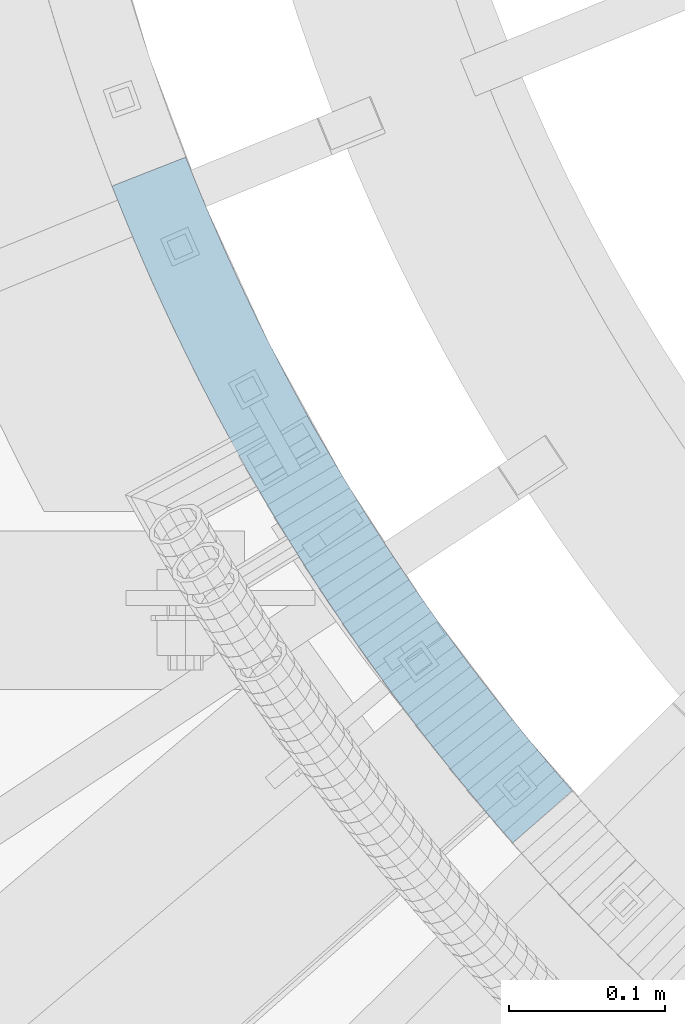
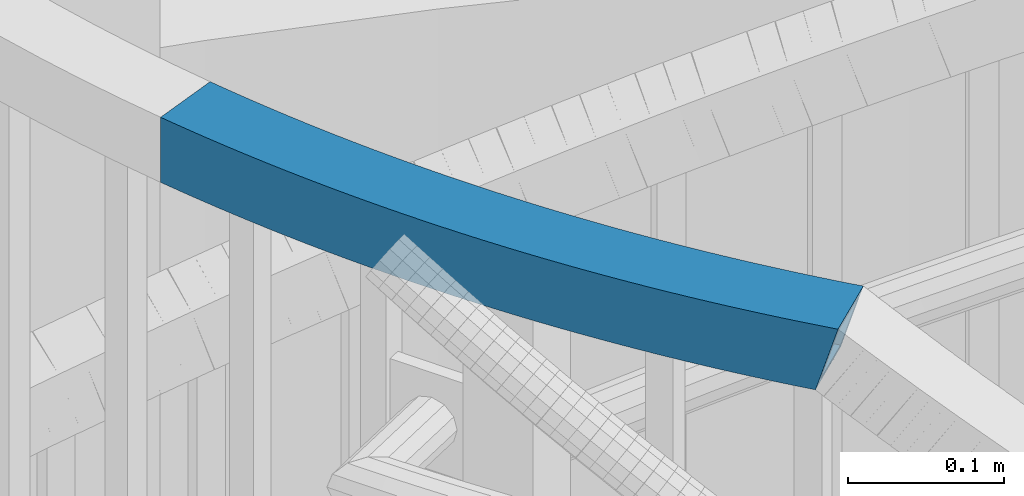
# One storey, part 475 of 975: 1 beam.
"""IFC2X3 building model written with IfcOpenShell, lengths in millimetres."""

from ifc_helpers import new_model, si_unit, frame, origin_with_axes, place, context, subcontext, project, spatial, faceted_brep, material, type_object, element, save


model = new_model("IFC2X3")

# Units and contexts
model_context = context("Model", 3, precision=1e-05, world=origin_with_axes())
body_context = subcontext(model_context, "Body", "Model", "MODEL_VIEW")
ifc_project = project(units=[si_unit("LENGTHUNIT", "METRE", prefix="MILLI"), si_unit("AREAUNIT", "SQUARE_METRE"), si_unit("VOLUMEUNIT", "CUBIC_METRE"), si_unit("MASSUNIT", "GRAM", prefix="KILO"), si_unit("TIMEUNIT", "SECOND"), si_unit("PLANEANGLEUNIT", "RADIAN"), si_unit("SOLIDANGLEUNIT", "STERADIAN"), si_unit("THERMODYNAMICTEMPERATUREUNIT", "DEGREE_CELSIUS"), si_unit("LUMINOUSINTENSITYUNIT", "LUMEN")], contexts=[model_context])

# Site, building, storey
site_placement = place(None, origin_with_axes())
site = spatial("IfcSite", under=ifc_project, at=site_placement, CompositionType="ELEMENT")
building_placement = place(site_placement, origin_with_axes())
building = spatial("IfcBuilding", under=site, at=building_placement, Name="Undefined", CompositionType="ELEMENT")
storey_placement = place(building_placement, origin_with_axes())
storey = spatial("IfcBuildingStorey", under=building, at=storey_placement, Name="Undefined", CompositionType="ELEMENT", Elevation=0.0)

# Beam
ifc_material = material()
beam_type = type_object("IfcBeamType", Name="HSS2X2X.188_TUBES", PredefinedType="NOTDEFINED")
beam_placement = place(storey_placement, frame((33730.3437735476, 2432.37434502385, 5130.8), z_axis=(0.0, 0.0, 1.0), x_axis=(-0.540589270770484, 0.841286657642825, 0.0)))
element("IfcBeam", 1, at=beam_placement, inside=storey, type_object=beam_type, material=ifc_material, Name="HANDRAIL", ObjectType="HSS2X2X.188_TUBES", context=body_context, shape_type="Brep", body=[
    faceted_brep([(79.5471046465154, 39.1947421820078, -25.3999999999996), (79.5471046465154, 39.1947421820078, 25.3999999999996), (88.9890045391239, 40.4672051726338, 25.3999999999996), (88.9890045391239, 40.4672051726338, -25.3999999999996), (98.4392155630703, 41.6763979808347, 25.3999999999996), (98.4392155630703, 41.6763979808347, -25.3999999999996), (107.897313749627, 42.8222663580855, 25.3999999999996), (107.897313749627, 42.8222663580855, -25.3999999999996), (117.362874776216, 43.9047588968242, 25.3999999999996), (117.362874776216, 43.9047588968242, -25.3999999999996), (126.835473985457, 44.9238270327405, 25.3999999999996), (126.835473985457, 44.9238270327405, -25.3999999999996), (136.314686404205, 45.8794250469546, 25.3999999999996), (136.314686404205, 45.8794250469546, -25.3999999999996), (145.800086762627, 46.7715100680834, 25.3999999999996), (145.800086762627, 46.7715100680834, -25.3999999999996), (155.291249513284, 47.6000420741329, 25.3999999999996), (155.291249513284, 47.6000420741329, -25.3999999999996), (164.787748850207, 48.3649838943456, 25.3999999999996), (164.787748850207, 48.3649838943456, -25.3999999999996), (174.289158728016, 49.0663012108089, 25.3999999999996), (174.289158728016, 49.0663012108089, -25.3999999999996), (183.795052881027, 49.7039625600446, 25.3999999999996), (183.795052881027, 49.7039625600446, -25.3999999999996), (193.30500484237, 50.2779393343772, 25.3999999999996), (193.30500484237, 50.2779393343772, -25.3999999999996), (202.818587963133, 50.7882057832503, 25.3999999999996), (202.818587963133, 50.7882057832503, -25.3999999999996), (212.335375431498, 51.2347390143768, 25.3999999999996), (212.335375431498, 51.2347390143768, -25.3999999999996), (221.854940291885, 51.6175189947426, 25.3999999999996), (221.854940291885, 51.6175189947426, -25.3999999999996), (231.376855464123, 51.9365285515378, 25.3999999999996), (231.376855464123, 51.9365285515378, -25.3999999999996), (240.900693762576, 52.191753372892, 25.3999999999996), (240.900693762576, 52.191753372892, -25.3999999999996), (250.426027915348, 52.3831820085652, 25.3999999999996), (250.426027915348, 52.3831820085652, -25.3999999999996), (259.952430583429, 52.5108058704027, 25.3999999999996), (259.952430583429, 52.5108058704027, -25.3999999999996), (269.479474379868, 52.5746192327679, 25.3999999999996), (269.479474379868, 52.5746192327679, -25.3999999999996), (279.00673188896, 52.5746192327751, 25.3999999999996), (279.00673188896, 52.5746192327751, -25.3999999999996), (288.533775685404, 52.5108058704245, 25.3999999999996), (288.533775685404, 52.5108058704245, -25.3999999999996), (298.060178353486, 52.3831820086016, 25.3999999999996), (298.060178353486, 52.3831820086016, -25.3999999999996), (307.585512506257, 52.1917533729429, 25.3999999999996), (307.585512506257, 52.1917533729429, -25.3999999999996), (317.109350804712, 51.9365285515996, 25.3999999999996), (317.109350804712, 51.9365285515996, -25.3999999999996), (326.631265976945, 51.6175189948226, 25.3999999999996), (326.631265976945, 51.6175189948226, -25.3999999999996), (336.150830837334, 51.2347390144678, 25.3999999999996), (336.150830837334, 51.2347390144678, -25.3999999999996), (345.667618305704, 50.7882057833631, 25.3999999999996), (345.667618305704, 50.7882057833631, -25.3999999999996), (355.181201426469, 50.2779393344972, 25.3999999999996), (355.181201426469, 50.2779393344972, -25.3999999999996), (364.69115338781, 49.7039625601756, 25.3999999999996), (364.69115338781, 49.7039625601756, -25.3999999999996), (374.197047540827, 49.0663012109617, 25.3999999999996), (374.197047540827, 49.0663012109617, -25.3999999999996), (383.698457418637, 48.3649838945094, 25.3999999999996), (383.698457418637, 48.3649838945094, -25.3999999999996), (393.19495675556, 47.6000420743076, 25.3999999999996), (393.19495675556, 47.6000420743076, -25.3999999999996), (402.686119506223, 46.771510068269, 25.3999999999996), (402.686119506223, 46.771510068269, -25.3999999999996), (412.171519864649, 45.8794250471583, 25.3999999999996), (412.171519864649, 45.8794250471583, -25.3999999999996), (421.650732283399, 44.9238270329552, 25.3999999999996), (421.650732283399, 44.9238270329552, -25.3999999999996), (431.123331492641, 43.9047588970534, 25.3999999999996), (431.123331492641, 43.9047588970534, -25.3999999999996), (440.588892519234, 42.8222663583329, 25.3999999999996), (440.588892519234, 42.8222663583329, -25.3999999999996), (450.046990705794, 41.676397981093, 25.3999999999996), (450.046990705794, 41.676397981093, -25.3999999999996), (459.497201729744, 40.4672051729103, 25.3999999999996), (459.497201729744, 40.4672051729103, -25.3999999999996), (468.939101622354, 39.1947421822952, 25.3999999999996), (468.939101622354, 39.1947421822952, -25.3999999999996), (478.372266787757, 37.8590660962946, 25.3999999999996), (478.372266787757, 37.8590660962946, -25.3999999999996), (487.796274021963, 36.4602368378837, 25.3999999999996), (487.796274021963, 36.4602368378837, -25.3999999999996), (497.210700531834, 34.9983171633285, 25.3999999999996), (497.210700531834, 34.9983171633285, -25.3999999999996), (506.615123954047, 33.4733726593295, 25.3999999999996), (506.615123954047, 33.4733726593295, -25.3999999999996), (516.00912237406, 31.8854717401045, 25.3999999999996), (516.00912237406, 31.8854717401045, -25.3999999999996), (525.39227434504, 30.2346856443182, 25.3999999999996), (525.39227434504, 30.2346856443182, -25.3999999999996), (534.764158906748, 28.5210884318549, 25.3999999999996), (534.764158906748, 28.5210884318549, -25.3999999999996), (544.124355604452, 26.744756980559, 25.3999999999996), (544.124355604452, 26.744756980559, -25.3999999999996), (534.485739444877, -23.1324630554082, 25.3999999999996), (534.485739444877, -23.1324630554082, -25.3999999999996), (543.499968030215, -24.9057709819099, -25.3999999999996), (543.499968030215, -24.9057709819099, 25.3999999999996), (525.459835486381, -21.4195720130774, 25.3999999999996), (525.459835486381, -21.4195720130774, -25.3999999999996), (516.422661087592, -19.7671747010645, 25.3999999999996), (516.422661087592, -19.7671747010645, -25.3999999999996), (507.374621687002, -18.175345251555, 25.3999999999996), (507.374621687002, -18.175345251555, -25.3999999999996), (498.316123210558, -16.644155079448, 25.3999999999996), (498.316123210558, -16.644155079448, -25.3999999999996), (489.247572053426, -15.1736728791657, 25.3999999999996), (489.247572053426, -15.1736728791657, -25.3999999999996), (480.169375061769, -13.7639646215539, 25.3999999999996), (480.169375061769, -13.7639646215539, -25.3999999999996), (471.081939514499, -12.4150935509497, 25.3999999999996), (471.081939514499, -12.4150935509497, -25.3999999999996), (461.985673105, -11.1271201823001, 25.3999999999996), (461.985673105, -11.1271201823001, -25.3999999999996), (452.880983922843, -9.90010229849213, 25.3999999999996), (452.880983922843, -9.90010229849213, -25.3999999999996), (443.768280435463, -8.73409494774387, 25.3999999999996), (443.768280435463, -8.73409494774387, -25.3999999999996), (434.647971469851, -7.62915044112378, 25.3999999999996), (434.647971469851, -7.62915044112378, -25.3999999999996), (425.520466194208, -6.58531835020767, 25.3999999999996), (425.520466194208, -6.58531835020767, -25.3999999999996), (416.386174099582, -5.60264550488137, 25.3999999999996), (416.386174099582, -5.60264550488137, -25.3999999999996), (407.245504981502, -4.68117599118341, 25.3999999999996), (407.245504981502, -4.68117599118341, -25.3999999999996), (398.09886892159, -3.82095114939875, 25.3999999999996), (398.09886892159, -3.82095114939875, -25.3999999999996), (388.946676269168, -3.02200957214518, 25.3999999999996), (388.946676269168, -3.02200957214518, -25.3999999999996), (379.789337622846, -2.2843871026671, 25.3999999999996), (379.789337622846, -2.2843871026671, -25.3999999999996), (370.627263812099, -1.60811683322754, 25.3999999999996), (370.627263812099, -1.60811683322754, -25.3999999999996), (361.460865878833, -0.993229103627527, 25.3999999999996), (361.460865878833, -0.993229103627527, -25.3999999999996), (352.290555058969, -0.439751499816339, 25.3999999999996), (352.290555058969, -0.439751499816339, -25.3999999999996), (343.116742763947, 0.0522911472980923, 25.3999999999996), (343.116742763947, 0.0522911472980923, -25.3999999999996), (333.939840562307, 0.482876763009699, 25.3999999999996), (333.939840562307, 0.482876763009699, -25.3999999999996), (324.760260161214, 0.851986029774707, 25.3999999999996), (324.760260161214, 0.851986029774707, -25.3999999999996), (315.578413387988, 1.1596023880993, 25.3999999999996), (315.578413387988, 1.1596023880993, -25.3999999999996), (306.394712171623, 1.40571203724903, 25.3999999999996), (306.394712171623, 1.40571203724903, -25.3999999999996), (297.209568524308, 1.59030393592184, 25.3999999999996), (297.209568524308, 1.59030393592184, -25.3999999999996), (288.023394522939, 1.71336980267733, 25.3999999999996), (288.023394522939, 1.71336980267733, -25.3999999999996), (278.836602290661, 1.77490411638064, 25.3999999999996), (278.836602290661, 1.77490411638064, -25.3999999999996), (269.649603978318, 1.77490411636609, 25.3999999999996), (269.649603978318, 1.77490411636609, -25.3999999999996), (260.462811746042, 1.71336980266278, 25.3999999999996), (260.462811746042, 1.71336980266278, -25.3999999999996), (251.276637744675, 1.59030393588546, 25.3999999999996), (251.276637744675, 1.59030393588546, -25.3999999999996), (242.091494097356, 1.40571203720174, 25.3999999999996), (242.091494097356, 1.40571203720174, -25.3999999999996), (232.907792880991, 1.15960238803382, 25.3999999999996), (232.907792880991, 1.15960238803382, -25.3999999999996), (223.725946107768, 0.851986029705586, 25.3999999999996), (223.725946107768, 0.851986029705586, -25.3999999999996), (214.546365706678, 0.482876762926026, 25.3999999999996), (214.546365706678, 0.482876762926026, -25.3999999999996), (205.36946350504, 0.0522911471962288, 25.3999999999996), (205.36946350504, 0.0522911471962288, -25.3999999999996), (196.195651210017, -0.439751499936392, 25.3999999999996), (196.195651210017, -0.439751499936392, -25.3999999999996), (187.02534039015, -0.993229103754857, 25.3999999999996), (187.02534039015, -0.993229103754857, -25.3999999999996), (177.858942456893, -1.60811683337306, 25.3999999999996), (177.858942456893, -1.60811683337306, -25.3999999999996), (168.696868646148, -2.28438710281989, 25.3999999999996), (168.696868646148, -2.28438710281989, -25.3999999999996), (159.539529999825, -3.02200957231253, 25.3999999999996), (159.539529999825, -3.02200957231253, -25.3999999999996), (150.387337347409, -3.82095114958065, 25.3999999999996), (150.387337347409, -3.82095114958065, -25.3999999999996), (141.240701287499, -4.68117599137986, 25.3999999999996), (141.240701287499, -4.68117599137986, -25.3999999999996), (132.100032169421, -5.60264550508509, 25.3999999999996), (132.100032169421, -5.60264550508509, -25.3999999999996), (122.965740074795, -6.58531835043686, 25.3999999999996), (122.965740074795, -6.58531835043686, -25.3999999999996), (113.838234799156, -7.62915044136025, 25.3999999999996), (113.838234799156, -7.62915044136025, -25.3999999999996), (104.717925833545, -8.73409494799853, 25.3999999999996), (104.717925833545, -8.73409494799853, -25.3999999999996), (95.6052223461702, -9.90010229876134, 25.3999999999996), (95.6052223461702, -9.90010229876134, -25.3999999999996), (86.500533164015, -11.127120182573, 25.3999999999996), (86.500533164015, -11.127120182573, -25.3999999999996), (68.3168312072576, -13.7639646218558, 25.3999999999996), (67.9397252692688, -13.8225235356222, 25.3999999999996), (68.3168312072576, -13.7639646218558, 24.1318825961562), (77.4042667545236, -12.4150935512334, 25.3999999999996), (77.4042667545236, -12.4150935512334, -6.39587451277657), (83.0671348327323, -11.6132675111185, -25.3999999999996), (553.472444507761, 24.905770982703, -25.3999999999996), (75.4261148838796, 38.6112362876302, -25.3999999999996), (70.1139394811162, 37.859066095989, 25.3999999999996), (70.1139394811162, 37.859066095989, -7.57277065792005), (60.6899322469162, 36.4602368375672, 25.3999999999996), (60.6899322469162, 36.4602368375672, 24.0856441217129), (60.2990761599049, 36.3995427312439, 25.3999999999996), (553.472444507761, 24.905770982703, 25.3999999999996), (80.1989885700332, 34.4770675853324, 20.6374999999998), (80.1989885700332, 34.4770675853324, -20.6374999999998), (89.6092749585368, 35.7452700971953, -20.6374999999998), (89.6092749585368, 35.7452700971953, 20.6374999999998), (99.0278446509274, 36.9504142687547, -20.6374999999998), (99.0278446509274, 36.9504142687547, 20.6374999999998), (108.45427509802, 38.0924460331371, -20.6374999999998), (108.45427509802, 38.0924460331371, 20.6374999999998), (117.888143397957, 39.1713141548935, -20.6374999999998), (117.888143397957, 39.1713141548935, 20.6374999999998), (127.329026315203, 40.1869702323165, -20.6374999999998), (127.329026315203, 40.1869702323165, 20.6374999999998), (136.776500299513, 41.1393686996053, -20.6374999999998), (136.776500299513, 41.1393686996053, 20.6374999999998), (146.230141504948, 42.0284668289205, -20.6374999999998), (146.230141504948, 42.0284668289205, 20.6374999999998), (155.689525808897, 42.8542247322803, -20.6374999999998), (155.689525808897, 42.8542247322803, 20.6374999999998), (165.154228831076, 43.6166053633569, -20.6374999999998), (165.154228831076, 43.6166053633569, 20.6374999999998), (174.6238259526, 44.3155745191725, -20.6374999999998), (174.6238259526, 44.3155745191725, 20.6374999999998), (184.09789233501, 44.9511008415648, -20.6374999999998), (184.09789233501, 44.9511008415648, 20.6374999999998), (193.576002939335, 45.5231558186606, -20.6374999999998), (193.576002939335, 45.5231558186606, 20.6374999999998), (203.057732545187, 46.0317137861239, -20.6374999999998), (203.057732545187, 46.0317137861239, 20.6374999999998), (212.542655769796, 46.4767519283014, -20.6374999999998), (212.542655769796, 46.4767519283014, 20.6374999999998), (222.030347087128, 46.8582502792706, -20.6374999999998), (222.030347087128, 46.8582502792706, 20.6374999999998), (231.520380846954, 47.1761917237091, -20.6374999999998), (231.520380846954, 47.1761917237091, 20.6374999999998), (241.012331293961, 47.4305619976731, -20.6374999999998), (241.012331293961, 47.4305619976731, 20.6374999999998), (250.505772586846, 47.6213496892524, -20.6374999999998), (250.505772586846, 47.6213496892524, 20.6374999999998), (260.000278817424, 47.7485462390505, -20.6374999999998), (260.000278817424, 47.7485462390505, 20.6374999999998), (269.495424029723, 47.8121459406029, -20.6374999999998), (269.495424029723, 47.8121459406029, 20.6374999999998), (278.99078223912, 47.8121459406175, -20.6374999999998), (278.99078223912, 47.8121459406175, 20.6374999999998), (288.485927451422, 47.7485462390759, -20.6374999999998), (288.485927451422, 47.7485462390759, 20.6374999999998), (297.980433682, 47.6213496892888, -20.6374999999998), (297.980433682, 47.6213496892888, 20.6374999999998), (307.473874974887, 47.4305619977204, -20.6374999999998), (307.473874974887, 47.4305619977204, 20.6374999999998), (316.965825421896, 47.1761917237709, -20.6374999999998), (316.965825421896, 47.1761917237709, 20.6374999999998), (326.455859181722, 46.8582502793433, -20.6374999999998), (326.455859181722, 46.8582502793433, 20.6374999999998), (335.943550499052, 46.476751928396, -20.6374999999998), (335.943550499052, 46.476751928396, 20.6374999999998), (345.428473723661, 46.0317137862257, -20.6374999999998), (345.428473723661, 46.0317137862257, 20.6374999999998), (354.910203329518, 45.5231558187807, -20.6374999999998), (354.910203329518, 45.5231558187807, 20.6374999999998), (364.388313933849, 44.9511008416994, -20.6374999999998), (364.388313933849, 44.9511008416994, 20.6374999999998), (373.862380316254, 44.3155745193144, -20.6374999999998), (373.862380316254, 44.3155745193144, 20.6374999999998), (383.331977437781, 43.6166053635243, -20.6374999999998), (383.331977437781, 43.6166053635243, 20.6374999999998), (392.796680459966, 42.8542247324549, -20.6374999999998), (392.796680459966, 42.8542247324549, 20.6374999999998), (402.256064763913, 42.0284668291097, -20.6374999999998), (402.256064763913, 42.0284668291097, 20.6374999999998), (411.709705969353, 41.139368699809, -20.6374999999998), (411.709705969353, 41.139368699809, 20.6374999999998), (421.157179953665, 40.1869702325312, -20.6374999999998), (421.157179953665, 40.1869702325312, 20.6374999999998), (430.598062870915, 39.1713141551227, -20.6374999999998), (430.598062870915, 39.1713141551227, 20.6374999999998), (440.031931170854, 38.0924460333845, -20.6374999999998), (440.031931170854, 38.0924460333845, 20.6374999999998), (449.458361617952, 36.9504142690203, -20.6374999999998), (449.458361617952, 36.9504142690203, 20.6374999999998), (458.876931310348, 35.7452700974682, -20.6374999999998), (458.876931310348, 35.7452700974682, 20.6374999999998), (468.287217698851, 34.4770675856162, -20.6374999999998), (468.287217698851, 34.4770675856162, 20.6374999999998), (477.688798605892, 33.1458636293646, -20.6374999999998), (477.688798605892, 33.1458636293646, 20.6374999999998), (487.081252244445, 31.7517179510614, -20.6374999999998), (487.081252244445, 31.7517179510614, 20.6374999999998), (496.464157236978, 30.2946930968428, -20.6374999999998), (496.464157236978, 30.2946930968428, 20.6374999999998), (505.837092634341, 28.7748544338137, -20.6374999999998), (505.837092634341, 28.7748544338137, 20.6374999999998), (515.199637934647, 27.1922701471376, -20.6374999999998), (515.199637934647, 27.1922701471376, 20.6374999999998), (524.551373102157, 25.5470112369403, -20.6374999999998), (524.551373102157, 25.5470112369403, 20.6374999999998), (533.891878586088, 23.8391515151488, -20.6374999999998), (533.891878586088, 23.8391515151488, 20.6374999999998), (543.22073533949, 22.0687676021844, -20.6374999999998), (543.22073533949, 22.0687676021844, 20.6374999999998), (552.537524837991, 20.2359389235207, -20.6374999999998), (552.537524837991, 20.2359389235207, 20.6374999999998), (544.434887699987, -20.2359389227277, 20.6374999999998), (544.434887699987, -20.2359389227277, -20.6374999999998), (535.389359709841, -18.4564736770335, -20.6374999999998), (535.389359709841, -18.4564736770335, 20.6374999999998), (526.332115807041, -16.7376350963677, -20.6374999999998), (526.332115807041, -16.7376350963677, 20.6374999999998), (517.263562330476, -15.0795002936866, -20.6374999999998), (517.263562330476, -15.0795002936866, 20.6374999999998), (508.184106126417, -13.482143658588, -20.6374999999998), (508.184106126417, -13.482143658588, 20.6374999999998), (499.094154530259, -11.9456368539431, -20.6374999999998), (499.094154530259, -11.9456368539431, 20.6374999999998), (489.994115348274, -10.4700488126837, -20.6374999999998), (489.994115348274, -10.4700488126837, 20.6374999999998), (480.884396839287, -9.05544573472798, -20.6374999999998), (480.884396839287, -9.05544573472798, 20.6374999999998), (471.765407696368, -7.7018910840161, -20.6374999999998), (471.765407696368, -7.7018910840161, 20.6374999999998), (462.6375570285, -6.40944558562114, -20.6374999999998), (462.6375570285, -6.40944558562114, 20.6374999999998), (453.50125434224, -5.17816722304997, -20.6374999999998), (453.50125434224, -5.17816722304997, 20.6374999999998), (444.356909523305, -4.00811123567109, -20.6374999999998), (444.356909523305, -4.00811123567109, 20.6374999999998), (435.204932818227, -2.89933011617904, -20.6374999999998), (435.204932818227, -2.89933011617904, 20.6374999999998), (426.045734815938, -1.85187360827695, -20.6374999999998), (426.045734815938, -1.85187360827695, 20.6374999999998), (416.879726429315, -0.865788704457373, -20.6374999999998), (416.879726429315, -0.865788704457373, 20.6374999999998), (407.707318876795, 0.0588803561549867, -20.6374999999998), (407.707318876795, 0.0588803561549867, 20.6374999999998), (398.528923663896, 0.922092089753278, -20.6374999999998), (398.528923663896, 0.922092089753278, 20.6374999999998), (389.344952564767, 1.72380776971113, -20.6374999999998), (389.344952564767, 1.72380776971113, 20.6374999999998), (380.155817603702, 2.46399142831797, -20.6374999999998), (380.155817603702, 2.46399142831797, 20.6374999999998), (370.961931036665, 3.14260985841247, -20.6374999999998), (370.961931036665, 3.14260985841247, 20.6374999999998), (361.763705332804, 3.75963261485958, -20.6374999999998), (361.763705332804, 3.75963261485958, 20.6374999999998), (352.561553155925, 4.31503201590021, -20.6374999999998), (352.561553155925, 4.31503201590021, 20.6374999999998), (343.355887345982, 4.80878314442452, -20.6374999999998), (343.355887345982, 4.80878314442452, 20.6374999999998), (334.147120900592, 5.24086384908514, -20.6374999999998), (334.147120900592, 5.24086384908514, 20.6374999999998), (324.935666956442, 5.61125474525033, -20.6374999999998), (324.935666956442, 5.61125474525033, 20.6374999999998), (315.721938770808, 5.91993921592803, -20.6374999999998), (315.721938770808, 5.91993921592803, 20.6374999999998), (306.506349702993, 6.16690341247522, -20.6374999999998), (306.506349702993, 6.16690341247522, 20.6374999999998), (297.289313195792, 6.35213625523465, -20.6374999999998), (297.289313195792, 6.35213625523465, 20.6374999999998), (288.071242756925, 6.47562943403318, -20.6374999999998), (288.071242756925, 6.47562943403318, 20.6374999999998), (278.852551940498, 6.5373774085383, -20.6374999999998), (278.852551940498, 6.5373774085383, 20.6374999999998), (269.633654328463, 6.53737740853103, -20.6374999999998), (269.633654328463, 6.53737740853103, 20.6374999999998), (260.414963512047, 6.47562943401499, -20.6374999999998), (260.414963512047, 6.47562943401499, 20.6374999999998), (251.196893073176, 6.35213625520191, -20.6374999999998), (251.196893073176, 6.35213625520191, 20.6374999999998), (241.979856565971, 6.16690341242793, -20.6374999999998), (241.979856565971, 6.16690341242793, 20.6374999999998), (232.764267498158, 5.91993921586254, -20.6374999999998), (232.764267498158, 5.91993921586254, 20.6374999999998), (223.550539312526, 5.61125474517394, -20.6374999999998), (223.550539312526, 5.61125474517394, 20.6374999999998), (214.33908536838, 5.24086384899419, -20.6374999999998), (214.33908536838, 5.24086384899419, 20.6374999999998), (205.130318922984, 4.80878314432266, -20.6374999999998), (205.130318922984, 4.80878314432266, 20.6374999999998), (195.92465311305, 4.3150320157838, -20.6374999999998), (195.92465311305, 4.3150320157838, 20.6374999999998), (186.72250093617, 3.75963261472498, -20.6374999999998), (186.72250093617, 3.75963261472498, 20.6374999999998), (177.524275232308, 3.14260985826695, -20.6374999999998), (177.524275232308, 3.14260985826695, 20.6374999999998), (168.330388665279, 2.46399142816153, -20.6374999999998), (168.330388665279, 2.46399142816153, 20.6374999999998), (159.141253704212, 1.72380776954014, -20.6374999999998), (159.141253704212, 1.72380776954014, 20.6374999999998), (149.957282605084, 0.922092089575017, -20.6374999999998), (149.957282605084, 0.922092089575017, 20.6374999999998), (140.778887392189, 0.0588803559621738, -20.6374999999998), (140.778887392189, 0.0588803559621738, 20.6374999999998), (131.606479839673, -0.865788704668375, -20.6374999999998), (131.606479839673, -0.865788704668375, 20.6374999999998), (122.440471453052, -1.85187360850614, -20.6374999999998), (122.440471453052, -1.85187360850614, 20.6374999999998), (113.281273450761, -2.89933011641551, -20.6374999999998), (113.281273450761, -2.89933011641551, 20.6374999999998), (104.129296745688, -4.00811123591848, -20.6374999999998), (104.129296745688, -4.00811123591848, 20.6374999999998), (94.9849519267627, -5.1781672233119, -20.6374999999998), (94.9849519267627, -5.1781672233119, 20.6374999999998), (85.8486492405009, -6.40944558589399, -20.6374999999998), (85.8486492405009, -6.40944558589399, 20.6374999999998), (76.72079857264, -7.70189108430714, 20.6374999999998), (80.9316547598228, -7.10566067677792, -20.6374999999998), (76.72079857264, -7.70189108430714, -6.50620852638349), (68.6407191594335, -8.90123773299638, 20.6374999999998), (70.7974076629962, 33.1458636290627, 20.6374999999998), (62.4326803682179, 31.9042659744882, 20.6374999999998), (70.7974076629962, 33.1458636290627, -7.46243664431313), (74.7233260513804, 33.7017486597106, -20.6374999999998)], [[[0, 1, 2, 3]], [[3, 2, 4, 5]], [[5, 4, 6, 7]], [[7, 6, 8, 9]], [[9, 8, 10, 11]], [[11, 10, 12, 13]], [[13, 12, 14, 15]], [[15, 14, 16, 17]], [[17, 16, 18, 19]], [[19, 18, 20, 21]], [[21, 20, 22, 23]], [[23, 22, 24, 25]], [[25, 24, 26, 27]], [[27, 26, 28, 29]], [[29, 28, 30, 31]], [[31, 30, 32, 33]], [[33, 32, 34, 35]], [[35, 34, 36, 37]], [[37, 36, 38, 39]], [[39, 38, 40, 41]], [[41, 40, 42, 43]], [[43, 42, 44, 45]], [[45, 44, 46, 47]], [[47, 46, 48, 49]], [[49, 48, 50, 51]], [[51, 50, 52, 53]], [[53, 52, 54, 55]], [[55, 54, 56, 57]], [[57, 56, 58, 59]], [[59, 58, 60, 61]], [[61, 60, 62, 63]], [[63, 62, 64, 65]], [[65, 64, 66, 67]], [[67, 66, 68, 69]], [[69, 68, 70, 71]], [[71, 70, 72, 73]], [[73, 72, 74, 75]], [[75, 74, 76, 77]], [[77, 76, 78, 79]], [[79, 78, 80, 81]], [[81, 80, 82, 83]], [[83, 82, 84, 85]], [[85, 84, 86, 87]], [[87, 86, 88, 89]], [[89, 88, 90, 91]], [[91, 90, 92, 93]], [[93, 92, 94, 95]], [[95, 94, 96, 97]], [[97, 96, 98, 99]], [[100, 101, 102, 103]], [[104, 105, 101, 100]], [[106, 107, 105, 104]], [[108, 109, 107, 106]], [[110, 111, 109, 108]], [[112, 113, 111, 110]], [[114, 115, 113, 112]], [[116, 117, 115, 114]], [[118, 119, 117, 116]], [[120, 121, 119, 118]], [[122, 123, 121, 120]], [[124, 125, 123, 122]], [[126, 127, 125, 124]], [[128, 129, 127, 126]], [[130, 131, 129, 128]], [[132, 133, 131, 130]], [[134, 135, 133, 132]], [[136, 137, 135, 134]], [[138, 139, 137, 136]], [[140, 141, 139, 138]], [[142, 143, 141, 140]], [[144, 145, 143, 142]], [[146, 147, 145, 144]], [[148, 149, 147, 146]], [[150, 151, 149, 148]], [[152, 153, 151, 150]], [[154, 155, 153, 152]], [[156, 157, 155, 154]], [[158, 159, 157, 156]], [[160, 161, 159, 158]], [[162, 163, 161, 160]], [[164, 165, 163, 162]], [[166, 167, 165, 164]], [[168, 169, 167, 166]], [[170, 171, 169, 168]], [[172, 173, 171, 170]], [[174, 175, 173, 172]], [[176, 177, 175, 174]], [[178, 179, 177, 176]], [[180, 181, 179, 178]], [[182, 183, 181, 180]], [[184, 185, 183, 182]], [[186, 187, 185, 184]], [[188, 189, 187, 186]], [[190, 191, 189, 188]], [[192, 193, 191, 190]], [[194, 195, 193, 192]], [[196, 197, 195, 194]], [[198, 199, 197, 196]], [[200, 201, 199, 198]], [[202, 203, 204]], [[205, 202, 204, 206]], [[201, 200, 205, 206, 207]], [[0, 3, 5, 7, 9, 11, 13, 15, 17, 19, 21, 23, 25, 27, 29, 31, 33, 35, 37, 39, 41, 43, 45, 47, 49, 51, 53, 55, 57, 59, 61, 63, 65, 67, 69, 71, 73, 75, 77, 79, 81, 83, 85, 87, 89, 91, 93, 95, 97, 99, 208, 102, 101, 105, 107, 109, 111, 113, 115, 117, 119, 121, 123, 125, 127, 129, 131, 133, 135, 137, 139, 141, 143, 145, 147, 149, 151, 153, 155, 157, 159, 161, 163, 165, 167, 169, 171, 173, 175, 177, 179, 181, 183, 185, 187, 189, 191, 193, 195, 197, 199, 201, 207, 209]], [[210, 1, 0, 209, 211]], [[212, 210, 211, 213]], [[212, 213, 214]], [[202, 205, 200, 198, 196, 194, 192, 190, 188, 186, 184, 182, 180, 178, 176, 174, 172, 170, 168, 166, 164, 162, 160, 158, 156, 154, 152, 150, 148, 146, 144, 142, 140, 138, 136, 134, 132, 130, 128, 126, 124, 122, 120, 118, 116, 114, 112, 110, 108, 106, 104, 100, 103, 215, 98, 96, 94, 92, 90, 88, 86, 84, 82, 80, 78, 76, 74, 72, 70, 68, 66, 64, 62, 60, 58, 56, 54, 52, 50, 48, 46, 44, 42, 40, 38, 36, 34, 32, 30, 28, 26, 24, 22, 20, 18, 16, 14, 12, 10, 8, 6, 4, 2, 1, 210, 212, 214, 203]], [[99, 98, 215, 208]], [[216, 217, 218, 219]], [[219, 218, 220, 221]], [[221, 220, 222, 223]], [[223, 222, 224, 225]], [[225, 224, 226, 227]], [[227, 226, 228, 229]], [[229, 228, 230, 231]], [[231, 230, 232, 233]], [[233, 232, 234, 235]], [[235, 234, 236, 237]], [[237, 236, 238, 239]], [[239, 238, 240, 241]], [[241, 240, 242, 243]], [[243, 242, 244, 245]], [[245, 244, 246, 247]], [[247, 246, 248, 249]], [[249, 248, 250, 251]], [[251, 250, 252, 253]], [[253, 252, 254, 255]], [[255, 254, 256, 257]], [[257, 256, 258, 259]], [[259, 258, 260, 261]], [[261, 260, 262, 263]], [[263, 262, 264, 265]], [[265, 264, 266, 267]], [[267, 266, 268, 269]], [[269, 268, 270, 271]], [[271, 270, 272, 273]], [[273, 272, 274, 275]], [[275, 274, 276, 277]], [[277, 276, 278, 279]], [[279, 278, 280, 281]], [[281, 280, 282, 283]], [[283, 282, 284, 285]], [[285, 284, 286, 287]], [[287, 286, 288, 289]], [[289, 288, 290, 291]], [[291, 290, 292, 293]], [[293, 292, 294, 295]], [[295, 294, 296, 297]], [[297, 296, 298, 299]], [[299, 298, 300, 301]], [[301, 300, 302, 303]], [[303, 302, 304, 305]], [[305, 304, 306, 307]], [[307, 306, 308, 309]], [[309, 308, 310, 311]], [[311, 310, 312, 313]], [[313, 312, 314, 315]], [[315, 314, 316, 317]], [[103, 102, 208, 215], [318, 317, 316, 319]], [[320, 321, 318, 319]], [[322, 323, 321, 320]], [[324, 325, 323, 322]], [[326, 327, 325, 324]], [[328, 329, 327, 326]], [[330, 331, 329, 328]], [[332, 333, 331, 330]], [[334, 335, 333, 332]], [[336, 337, 335, 334]], [[338, 339, 337, 336]], [[340, 341, 339, 338]], [[342, 343, 341, 340]], [[344, 345, 343, 342]], [[346, 347, 345, 344]], [[348, 349, 347, 346]], [[350, 351, 349, 348]], [[352, 353, 351, 350]], [[354, 355, 353, 352]], [[356, 357, 355, 354]], [[358, 359, 357, 356]], [[360, 361, 359, 358]], [[362, 363, 361, 360]], [[364, 365, 363, 362]], [[366, 367, 365, 364]], [[368, 369, 367, 366]], [[370, 371, 369, 368]], [[372, 373, 371, 370]], [[374, 375, 373, 372]], [[376, 377, 375, 374]], [[378, 379, 377, 376]], [[380, 381, 379, 378]], [[382, 383, 381, 380]], [[384, 385, 383, 382]], [[386, 387, 385, 384]], [[388, 389, 387, 386]], [[390, 391, 389, 388]], [[392, 393, 391, 390]], [[394, 395, 393, 392]], [[396, 397, 395, 394]], [[398, 399, 397, 396]], [[400, 401, 399, 398]], [[402, 403, 401, 400]], [[404, 405, 403, 402]], [[406, 407, 405, 404]], [[408, 409, 407, 406]], [[410, 411, 409, 408]], [[412, 413, 411, 410]], [[414, 415, 413, 412]], [[416, 417, 415, 414]], [[418, 419, 417, 416]], [[420, 419, 418, 421, 422]], [[420, 422, 423]], [[424, 216, 219, 221, 223, 225, 227, 229, 231, 233, 235, 237, 239, 241, 243, 245, 247, 249, 251, 253, 255, 257, 259, 261, 263, 265, 267, 269, 271, 273, 275, 277, 279, 281, 283, 285, 287, 289, 291, 293, 295, 297, 299, 301, 303, 305, 307, 309, 311, 313, 315, 317, 318, 321, 323, 325, 327, 329, 331, 333, 335, 337, 339, 341, 343, 345, 347, 349, 351, 353, 355, 357, 359, 361, 363, 365, 367, 369, 371, 373, 375, 377, 379, 381, 383, 385, 387, 389, 391, 393, 395, 397, 399, 401, 403, 405, 407, 409, 411, 413, 415, 417, 419, 420, 423, 425]], [[424, 425, 426]], [[217, 216, 424, 426, 427]], [[418, 416, 414, 412, 410, 408, 406, 404, 402, 400, 398, 396, 394, 392, 390, 388, 386, 384, 382, 380, 378, 376, 374, 372, 370, 368, 366, 364, 362, 360, 358, 356, 354, 352, 350, 348, 346, 344, 342, 340, 338, 336, 334, 332, 330, 328, 326, 324, 322, 320, 319, 316, 314, 312, 310, 308, 306, 304, 302, 300, 298, 296, 294, 292, 290, 288, 286, 284, 282, 280, 278, 276, 274, 272, 270, 268, 266, 264, 262, 260, 258, 256, 254, 252, 250, 248, 246, 244, 242, 240, 238, 236, 234, 232, 230, 228, 226, 224, 222, 220, 218, 217, 427, 421]], [[204, 203, 214, 213, 211, 209, 207, 206], [426, 425, 423, 422, 421, 427]]]),
])

save(model, "model.ifc")
